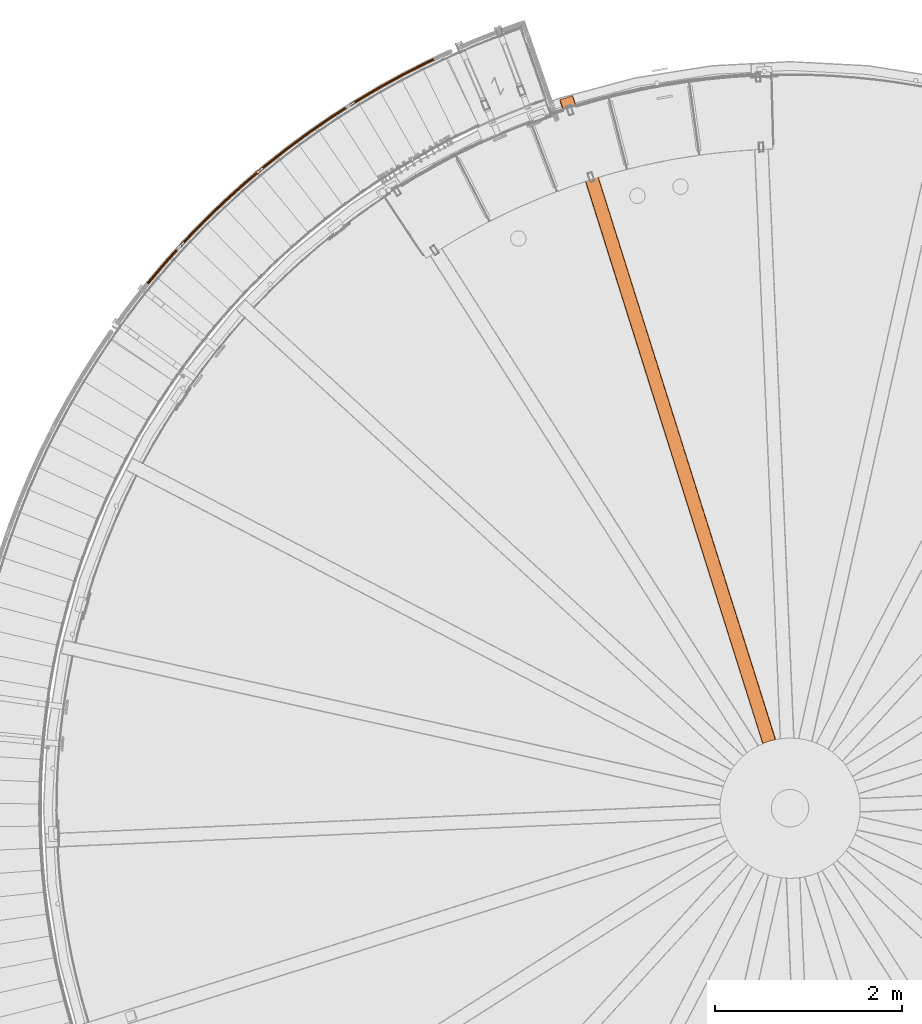
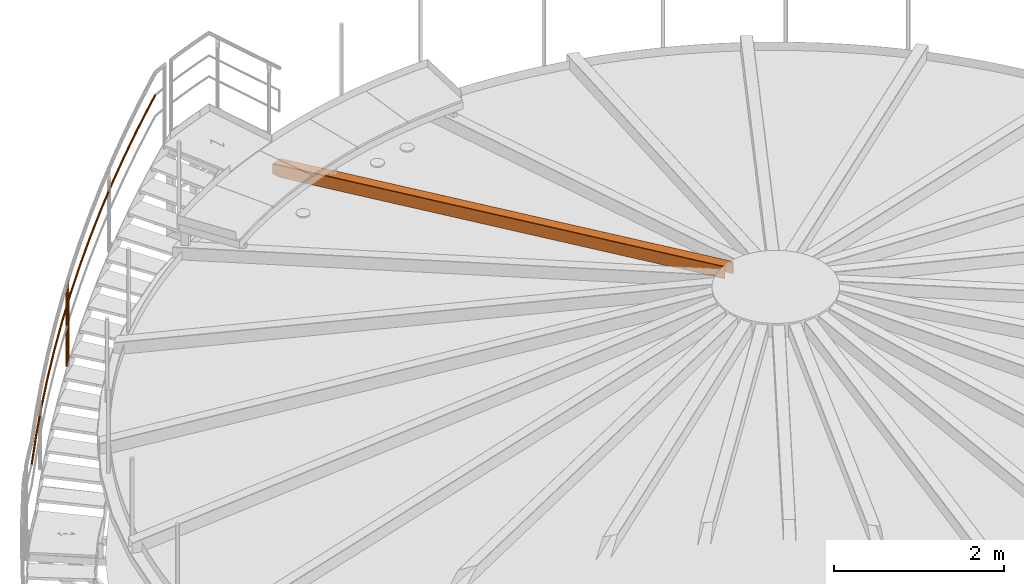
# One storey, part 35 of 126: 3 proxies.
"""IFC2X3 building model written with IfcOpenShell, lengths in millimetres."""

from ifc_helpers import new_model, si_unit, origin, origin_with_axes, place, context, project, spatial, faceted_brep, material, element, save


model = new_model("IFC2X3")

# Units and contexts
context_of_model_1 = context(None, 3, precision=0.1, world=origin())
context_of_model_2 = context(None, 3, precision=0.1, world=origin())
ifc_project = project(units=[si_unit("LENGTHUNIT", "METRE", prefix="MILLI"), si_unit("AREAUNIT", "SQUARE_METRE", prefix="CENTI"), si_unit("VOLUMEUNIT", "CUBIC_METRE", prefix="CENTI"), si_unit("MASSUNIT", "GRAM", prefix="KILO")], contexts=[context_of_model_1, context_of_model_2])

# Site, building, storey
site_placement = place(None, origin_with_axes())
site = spatial("IfcSite", under=ifc_project, at=site_placement, CompositionType="ELEMENT")
building_placement = place(site_placement, origin_with_axes())
building = spatial("IfcBuilding", under=site, at=building_placement, CompositionType="ELEMENT")
storey_placement = place(building_placement, origin_with_axes())
storey = spatial("IfcBuildingStorey", under=building, at=storey_placement, CompositionType="ELEMENT")

# Proxies
ifc_material_1 = material(Name="STAHL")
proxy_1_placement = place(storey_placement, origin_with_axes())
element("IfcBuildingElementProxy", 1, at=proxy_1_placement, inside=storey, material=ifc_material_1, Name="profile", context=context_of_model_2, shape_type="Brep", body=[
    faceted_brep([(7710.0, 8694.5, 12406.2), (7713.7, 8696.1, 12406.1), (7713.7, 8696.1, 12573.8), (7713.8, 8696.1, 12574.5), (7713.9, 8696.2, 12575.2), (7714.2, 8696.3, 12576.0), (7714.7, 8696.5, 12576.6), (7715.2, 8696.7, 12577.1), (7715.8, 8697.0, 12577.5), (7716.5, 8697.3, 12577.8), (7717.4, 8697.7, 12577.9), (7779.5, 8720.3, 12577.1), (7845.3, 8737.8, 12577.9), (7845.7, 8737.9, 12577.9), (7846.1, 8738.0, 12577.8), (7846.9, 8738.2, 12577.6), (7847.7, 8738.3, 12577.1), (7848.2, 8738.4, 12576.5), (7848.7, 8738.5, 12575.8), (7849.1, 8738.6, 12574.9), (7849.2, 8738.6, 12573.9), (7849.2, 8738.6, 12406.2), (7853.1, 8739.5, 12406.3), (7853.1, 8739.5, 12574.0), (7853.0, 8739.4, 12575.4), (7852.6, 8739.4, 12576.8), (7852.0, 8739.2, 12578.2), (7851.1, 8739.0, 12579.5), (7850.0, 8738.8, 12580.5), (7848.7, 8738.5, 12581.3), (7847.1, 8738.2, 12581.9), (7845.3, 8737.8, 12582.1), (7779.5, 8720.3, 12581.2), (7717.4, 8697.7, 12582.0), (7716.6, 8697.3, 12582.0), (7715.7, 8697.0, 12581.8), (7714.2, 8696.3, 12581.3), (7712.9, 8695.8, 12580.4), (7711.8, 8695.3, 12579.2), (7710.9, 8694.9, 12577.8), (7710.2, 8694.6, 12576.0), (7710.0, 8694.5, 12573.9), (5540.8, 15574.3, 10506.0), (5540.8, 15574.3, 10641.0), (5541.0, 15574.4, 10642.6), (5541.4, 15574.5, 10644.2), (5542.3, 15574.8, 10645.9), (5543.5, 15575.2, 10647.3), (5545.0, 15575.6, 10648.4), (5546.7, 15576.2, 10649.1), (5548.4, 15576.7, 10649.3), (5676.2, 15617.0, 10649.3), (5677.7, 15617.5, 10649.2), (5679.2, 15618.0, 10648.7), (5680.7, 15618.4, 10647.7), (5682.0, 15618.9, 10646.4), (5683.0, 15619.2, 10644.8), (5683.7, 15619.4, 10643.0), (5683.9, 15619.4, 10641.0), (5683.9, 15619.4, 10506.0), (5680.0, 15618.2, 10506.0), (5680.0, 15618.2, 10641.0), (5680.0, 15618.2, 10641.8), (5679.8, 15618.1, 10642.6), (5679.3, 15618.0, 10643.5), (5678.7, 15617.8, 10644.2), (5678.0, 15617.6, 10644.7), (5677.1, 15617.3, 10645.1), (5676.2, 15617.0, 10645.2), (5548.4, 15576.7, 10645.2), (5547.7, 15576.5, 10645.1), (5547.0, 15576.3, 10644.9), (5546.2, 15576.0, 10644.4), (5545.5, 15575.8, 10643.7), (5545.0, 15575.7, 10642.9), (5544.7, 15575.6, 10642.0), (5544.6, 15575.5, 10641.0), (5544.6, 15575.5, 10506.0), (5716.7, 15501.9, 10506.0), (5720.5, 15503.1, 10506.0), (5577.5, 15458.0, 10506.0), (5581.3, 15459.2, 10506.0)], [[[0, 1, 2, 3, 4, 5, 6, 7, 8, 9, 10, 11, 12, 13, 14, 15, 16, 17, 18, 19, 20, 21, 22, 23, 24, 25, 26, 27, 28, 29, 30, 31, 32, 33, 34, 35, 36, 37, 38, 39, 40, 41]], [[42, 43, 44, 45, 46, 47, 48, 49, 50, 51, 52, 53, 54, 55, 56, 57, 58, 59, 60, 61, 62, 63, 64, 65, 66, 67, 68, 69, 70, 71, 72, 73, 74, 75, 76, 77]], [[21, 78, 79, 22]], [[24, 23, 22, 79, 59, 58, 57]], [[26, 25, 24, 57, 56]], [[26, 56, 55, 27]], [[27, 55, 54, 28]], [[29, 28, 54, 53]], [[30, 29, 53, 52]], [[35, 34, 33, 32, 31, 30, 52, 51, 50, 49]], [[36, 35, 49, 48]], [[37, 36, 48, 47]], [[38, 37, 47, 46]], [[39, 38, 46, 45]], [[40, 39, 45, 44]], [[0, 41, 40, 44, 43, 42, 80]], [[1, 0, 80, 81]], [[77, 81, 80, 42]], [[60, 59, 79, 78]], [[19, 62, 61, 60, 78, 21, 20]], [[19, 18, 63, 62]], [[18, 17, 64, 63]], [[17, 16, 65, 64]], [[16, 15, 66, 65]], [[15, 14, 67, 66]], [[9, 70, 69, 68, 67, 14, 13, 12, 11, 10]], [[9, 8, 71, 70]], [[8, 7, 72, 71]], [[6, 73, 72, 7]], [[5, 74, 73, 6]], [[3, 75, 74, 5, 4]], [[2, 1, 81, 77, 76, 75, 3]]]),
])
ifc_material_2 = material(Name="S235JRG2")
proxy_2_placement = place(storey_placement, origin_with_axes())
element("IfcBuildingElementProxy", 2, at=proxy_2_placement, inside=storey, material=ifc_material_2, context=context_of_model_2, shape_type="Brep", body=[
    faceted_brep([(1138.8066, 13610.681, 9090.2317), (1134.2211, 13615.725, 9088.8115), (1124.8423, 13603.861, 9078.1524), (1129.9924, 13599.531, 9080.2142), (1132.1521, 13621.046, 9084.8264), (1121.7807, 13607.926, 9073.0392), (1133.1539, 13625.219, 9079.3441), (1121.6279, 13610.638, 9066.2446), (1136.9581, 13627.126, 9073.8336), (1124.4248, 13611.271, 9059.5892), (1142.5454, 13626.255, 9069.7715), (1129.422, 13609.654, 9054.8564), (1148.4187, 13622.841, 9068.2461), (1135.2805, 13606.221, 9053.3143), (1153.0042, 13617.797, 9069.6662), (1140.4306, 13601.891, 9055.376), (1155.0732, 13612.476, 9073.6513), (1143.4922, 13597.826, 9060.4893), (1154.0714, 13608.303, 9079.1336), (1143.645, 13595.113, 9067.2839), (1150.2671, 13606.396, 9084.6441), (1140.8481, 13594.481, 9073.9392), (1144.6798, 13607.267, 9088.7063), (1135.8509, 13596.098, 9078.672), (1139.5212, 13611.585, 9088.597), (1144.5211, 13608.678, 9087.2985), (1135.3729, 13597.106, 9076.9014), (1130.3856, 13600.029, 9078.2142), (1149.2776, 13607.937, 9083.8404), (1139.6271, 13595.729, 9072.8723), (1152.5162, 13609.56, 9079.1493), (1142.0081, 13596.268, 9067.2066), (1153.369, 13613.113, 9074.4822), (1141.878, 13598.577, 9061.4223), (1151.6077, 13617.643, 9071.0897), (1139.2716, 13602.038, 9057.0695), (1147.704, 13621.937, 9069.8807), (1134.8873, 13605.723, 9055.3143), (1142.7041, 13624.843, 9071.1793), (1129.9, 13608.646, 9056.6271), (1137.9476, 13625.584, 9074.6374), (1125.6458, 13610.022, 9060.6561), (1134.7091, 13623.961, 9079.3285), (1123.2648, 13609.484, 9066.3219), (1133.8562, 13620.409, 9083.9956), (1123.395, 13607.175, 9072.1061), (1135.6176, 13615.879, 9087.3881), (1126.0013, 13603.714, 9076.459), (1328.8909, 13835.767, 9297.8784), (1324.4755, 13840.96, 9296.4583), (1322.5845, 13846.347, 9292.4731), (1323.7245, 13850.484, 9286.9908), (1327.5901, 13852.263, 9281.4803), (1333.1453, 13851.208, 9277.4182), (1338.9018, 13847.6, 9275.8928), (1343.3171, 13842.407, 9277.3129), (1345.2082, 13837.02, 9281.298), (1344.0683, 13832.882, 9286.7803), (1340.2028, 13831.103, 9292.2908), (1334.6475, 13832.159, 9296.353), (1329.6352, 13836.646, 9296.2438), (1334.5358, 13833.575, 9294.9452), (1339.265, 13832.676, 9291.487), (1342.5557, 13834.191, 9286.7959), (1343.5261, 13837.713, 9282.1289), (1341.9163, 13842.299, 9278.7364), (1338.1575, 13846.72, 9277.5275), (1333.257, 13849.791, 9278.826), (1328.5278, 13850.69, 9282.2841), (1325.2371, 13849.176, 9286.9752), (1324.2666, 13845.654, 9291.6423), (1325.8764, 13841.067, 9295.0348), (1526.3504, 14054.411, 9505.5251), (1522.1101, 14059.748, 9504.105), (1520.3991, 14065.195, 9500.1198), (1521.676, 14069.292, 9494.6375), (1525.5986, 14070.942, 9489.1271), (1531.1157, 14069.702, 9485.0649), (1536.7491, 14065.905, 9483.5396), (1540.9894, 14060.568, 9484.9597), (1542.7004, 14055.121, 9488.9447), (1541.4236, 14051.024, 9494.427), (1537.5011, 14049.374, 9499.9375), (1531.984, 14050.614, 9503.9997), (1527.1236, 14055.265, 9503.8905), (1531.9194, 14052.033, 9502.592), (1536.6162, 14050.978, 9499.1338), (1539.9554, 14052.382, 9494.4427), (1541.0423, 14055.87, 9489.7756), (1539.5857, 14060.507, 9486.3831), (1535.976, 14065.05, 9485.1742), (1531.1802, 14068.283, 9486.4727), (1526.4835, 14069.338, 9489.9308), (1523.1442, 14067.934, 9494.6219), (1522.0572, 14064.446, 9499.289), (1523.5138, 14059.809, 9502.6816), (1730.967, 14266.372, 9713.1719), (1726.9064, 14271.847, 9711.7517), (1725.3774, 14277.348, 9707.7666), (1726.7897, 14281.401, 9702.2843), (1730.7649, 14282.919, 9696.7738), (1736.2378, 14281.497, 9692.7117), (1741.7419, 14277.514, 9691.1863), (1745.8025, 14272.039, 9692.6064), (1747.3315, 14266.539, 9696.5915), (1745.9193, 14262.486, 9702.0738), (1741.9442, 14260.968, 9707.5843), (1736.4712, 14262.39, 9711.6465), (1731.7681, 14267.201, 9711.5373), (1736.4539, 14263.811, 9710.2387), (1741.113, 14262.6, 9706.7805), (1744.497, 14263.892, 9702.0894), (1745.6993, 14267.342, 9697.4224), (1744.3976, 14272.025, 9694.0299), (1740.9408, 14276.686, 9692.821), (1736.2551, 14280.076, 9694.1195), (1731.5961, 14281.287, 9697.5776), (1728.212, 14279.994, 9702.2686), (1727.0097, 14276.544, 9706.9357), (1728.3113, 14271.862, 9710.3283), (1942.5146, 14471.416, 9920.8186), (1938.6382, 14477.023, 9919.3985), (1937.2929, 14482.572, 9915.4133), (1938.8391, 14486.575, 9909.931), (1942.8625, 14487.961, 9904.4206), (1948.2851, 14486.357, 9900.3584), (1953.6539, 14482.194, 9898.8331), (1957.5302, 14476.588, 9900.2532), (1958.8756, 14471.039, 9904.2382), (1957.3295, 14467.036, 9909.7205), (1953.3061, 14465.65, 9915.231), (1947.8835, 14467.254, 9919.2932), (1943.3428, 14472.218, 9919.184), (1947.9133, 14468.674, 9917.8854), (1952.5296, 14467.309, 9914.4273), (1955.9547, 14468.488, 9909.7362), (1957.271, 14471.897, 9905.0691), (1956.1256, 14476.62, 9901.6766), (1952.8257, 14481.393, 9900.4677), (1948.2552, 14484.937, 9901.7662), (1943.639, 14486.302, 9905.2243), (1940.2138, 14485.123, 9909.9154), (1938.8975, 14481.715, 9914.5825), (1940.0428, 14476.991, 9917.9751), (2160.7596, 14669.317, 10128.465), (2157.0716, 14675.05, 10127.045), (2155.9114, 14680.64, 10123.06), (2157.5898, 14684.59, 10117.578), (2161.6571, 14685.841, 10112.067), (2167.0234, 14684.058, 10108.005), (2172.2508, 14679.719, 10106.48), (2175.9387, 14673.986, 10107.9), (2177.099, 14668.396, 10111.885), (2175.4206, 14664.446, 10117.367), (2171.3534, 14663.195, 10122.878), (2165.9871, 14664.978, 10126.94), (2161.6139, 14670.091, 10126.831), (2166.0641, 14666.397, 10125.532), (2170.6325, 14664.879, 10122.074), (2174.0949, 14665.944, 10117.383), (2175.5237, 14669.307, 10112.716), (2174.536, 14674.066, 10109.323), (2171.3964, 14678.946, 10108.114), (2166.9463, 14682.639, 10109.413), (2162.378, 14684.157, 10112.871), (2158.9155, 14683.092, 10117.562), (2157.4867, 14679.73, 10122.229), (2158.4744, 14674.971, 10125.622), (2385.4607, 14859.856, 10336.112), (2381.9653, 14865.708, 10334.692), (2380.9915, 14871.334, 10330.707), (2382.8003, 14875.225, 10325.225), (2386.9069, 14876.341, 10319.714), (2392.2109, 14874.38, 10315.652), (2397.2913, 14869.87, 10314.127), (2400.7866, 14864.018, 10315.547), (2401.7605, 14858.392, 10319.532), (2399.9518, 14854.501, 10325.014), (2395.8453, 14853.385, 10330.525), (2390.5411, 14855.345, 10334.587), (2386.3403, 14860.6, 10334.478), (2390.6653, 14856.761, 10333.179), (2395.1807, 14855.092, 10329.721), (2398.6766, 14856.041, 10325.03), (2400.2163, 14859.354, 10320.363), (2399.3873, 14864.144, 10316.97), (2396.4117, 14869.125, 10315.761), (2392.0868, 14872.965, 10317.06), (2387.5714, 14874.634, 10320.518), (2384.0755, 14873.684, 10325.209), (2382.5357, 14870.371, 10329.876), (2383.3646, 14865.582, 10333.269), (2616.3698, 15042.822, 10543.759), (2613.0708, 15048.787, 10542.339), (2612.2845, 15054.442, 10538.354), (2614.2216, 15058.271, 10532.871), (2618.363, 15059.249, 10527.361), (2623.599, 15057.114, 10523.299), (2628.5267, 15052.437, 10521.773), (2631.8256, 15046.472, 10523.193), (2632.612, 15040.817, 10527.179), (2630.675, 15036.988, 10532.661), (2626.5336, 15036.01, 10538.171), (2621.2976, 15038.145, 10542.234), (2617.2737, 15043.537, 10542.124), (2621.4687, 15039.555, 10540.826), (2625.9261, 15037.737, 10537.368), (2629.4517, 15038.57, 10532.676), (2631.1006, 15041.83, 10528.009), (2630.4312, 15046.644, 10524.617), (2627.6228, 15051.722, 10523.408), (2623.4279, 15055.704, 10524.707), (2618.9705, 15057.522, 10528.165), (2615.4449, 15056.689, 10532.856), (2613.7959, 15053.429, 10537.523), (2614.4652, 15048.615, 10540.915), (2853.2318, 15218.013, 10751.406), (2850.1329, 15224.084, 10749.986), (2849.535, 15229.762, 10746.0), (2851.5983, 15233.525, 10740.518), (2855.7699, 15234.365, 10735.008), (2860.932, 15232.057, 10730.945), (2865.7015, 15227.219, 10729.42), (2868.8004, 15221.148, 10730.84), (2869.3984, 15215.47, 10734.825), (2867.3352, 15211.707, 10740.308), (2863.1636, 15210.867, 10745.818), (2858.0014, 15213.175, 10749.88), (2854.159, 15218.697, 10749.771), (2858.2193, 15214.579, 10748.472), (2862.6139, 15212.614, 10745.014), (2866.1652, 15213.329, 10740.323), (2867.9216, 15216.532, 10735.656), (2867.4125, 15221.366, 10732.264), (2864.7744, 15226.535, 10731.055), (2860.7141, 15230.653, 10732.353), (2856.3196, 15232.618, 10735.811), (2852.7683, 15231.903, 10740.502), (2851.0118, 15228.7, 10745.17), (2851.5208, 15223.866, 10748.562), (3095.7851, 15385.236, 10959.052), (3092.8896, 15391.407, 10957.632), (3092.4807, 15397.101, 10953.647), (3094.6679, 15400.794, 10948.165), (3098.8652, 15401.495, 10942.654), (3103.9477, 15399.016, 10938.592), (3108.5538, 15394.022, 10937.067), (3111.4493, 15387.852, 10938.487), (3111.8582, 15382.157, 10942.472), (3109.6711, 15378.464, 10947.954), (3105.4739, 15377.763, 10953.465), (3100.3913, 15380.242, 10957.527), (3096.7344, 15385.889, 10957.418), (3100.6557, 15381.638, 10956.119), (3104.9825, 15379.528, 10952.661), (3108.5556, 15380.125, 10947.97), (3110.4175, 15383.268, 10943.303), (3110.0694, 15388.116, 10939.91), (3107.6045, 15393.369, 10938.701), (3103.6833, 15397.62, 10940.0), (3099.3565, 15399.73, 10943.458), (3095.7834, 15399.134, 10948.149), (3093.9214, 15395.99, 10952.816), (3094.2695, 15391.142, 10956.209), (3343.7616, 15544.306, 11166.699), (3341.0729, 15550.569, 11165.279), (3340.8534, 15556.275, 11161.294), (3343.1621, 15559.892, 11155.812), (3347.3803, 15560.453, 11150.301), (3352.3777, 15557.807, 11146.239), (3356.8153, 15552.663, 11144.714), (3359.5041, 15546.399, 11146.134), (3359.7236, 15540.694, 11150.119), (3357.4149, 15537.076, 11155.601), (3353.1968, 15536.515, 11161.112), (3348.1993, 15539.161, 11165.174), (3344.7322, 15544.927, 11165.065), (3348.51, 15540.548, 11163.766), (3352.7643, 15538.295, 11160.308), (3356.3552, 15538.773, 11155.617), (3358.3206, 15541.853, 11150.95), (3358.1337, 15546.709, 11147.557), (3355.8448, 15552.042, 11146.348), (3352.067, 15556.421, 11147.647), (3347.8127, 15558.673, 11151.105), (3344.2218, 15558.196, 11155.796), (3342.2564, 15555.116, 11160.463), (3342.4432, 15550.259, 11163.856), (3596.8875, 15695.047, 11374.346), (3594.4084, 15701.396, 11372.926), (3594.3787, 15707.106, 11368.941), (3596.8063, 15710.645, 11363.458), (3601.0408, 15711.065, 11357.948), (3605.9475, 15708.254, 11353.886), (3610.2117, 15702.966, 11352.36), (3612.6908, 15696.616, 11353.78), (3612.7206, 15690.907, 11357.766), (3610.293, 15687.368, 11363.248), (3606.0586, 15686.947, 11368.758), (3601.1518, 15689.758, 11372.821), (3597.8782, 15695.635, 11372.711), (3601.5083, 15691.133, 11371.413), (3605.6855, 15688.74, 11367.955), (3609.2903, 15689.098, 11363.263), (3611.3569, 15692.111, 11358.596), (3611.3315, 15696.971, 11355.204), (3609.2211, 15702.377, 11353.995), (3605.591, 15706.879, 11355.294), (3601.4139, 15709.272, 11358.752), (3597.809, 15708.914, 11363.443), (3595.7424, 15705.901, 11368.11), (3595.7677, 15701.041, 11371.502), (3854.8831, 15837.292, 11581.993), (3852.6163, 15843.721, 11580.573), (3852.7764, 15849.428, 11576.587), (3855.3203, 15852.884, 11571.105), (3859.5664, 15853.164, 11565.594), (3864.377, 15850.192, 11561.532), (3868.4631, 15844.764, 11560.007), (3870.7298, 15838.336, 11561.427), (3870.5699, 15832.629, 11565.412), (3868.026, 15829.172, 11570.895), (3863.7799, 15828.893, 11576.405), (3858.9693, 15831.865, 11580.467), (3855.8928, 15837.848, 11580.358), (3859.3713, 15833.227, 11579.059), (3863.4666, 15830.697, 11575.601), (3867.0813, 15830.935, 11570.91), (3869.2469, 15833.878, 11566.243), (3869.3831, 15838.736, 11562.851), (3867.4534, 15844.209, 11561.642), (3863.975, 15848.829, 11562.94), (3859.8797, 15851.359, 11566.398), (3856.265, 15851.121, 11571.089), (3854.0993, 15848.179, 11575.757), (3853.9631, 15843.32, 11579.149), (4117.4634, 15970.886, 11789.639), (4115.4115, 15977.386, 11788.219), (4115.7611, 15983.085, 11784.234), (4118.4185, 15986.454, 11778.752), (4122.6716, 15986.593, 11773.241), (4127.3807, 15983.462, 11769.179), (4131.2842, 15977.902, 11767.654), (4133.336, 15971.402, 11769.074), (4132.9865, 15965.703, 11773.059), (4130.3292, 15962.333, 11778.541), (4126.0761, 15962.195, 11784.052), (4121.3669, 15965.325, 11788.114), (4118.4909, 15971.407, 11788.005), (4121.814, 15966.674, 11786.706), (4125.823, 15964.009, 11783.248), (4129.4436, 15964.127, 11778.557), (4131.7058, 15966.995, 11773.89), (4132.0034, 15971.847, 11770.497), (4130.2566, 15977.38, 11769.288), (4126.9336, 15982.114, 11770.587), (4122.9247, 15984.779, 11774.045), (4119.304, 15984.661, 11778.736), (4117.0418, 15981.792, 11783.403), (4116.7442, 15976.941, 11786.796), (4197.2202, 16008.181, 11851.696), (4194.9624, 16014.574, 11850.065), (4194.3236, 16019.78, 11845.268), (4195.4744, 16022.405, 11838.591), (4198.1066, 16021.747, 11831.821), (4201.5151, 16017.981, 11826.772), (4204.7873, 16012.116, 11824.796), (4207.0464, 16005.722, 11826.424), (4207.6866, 16000.513, 11831.22), (4206.5358, 15997.886, 11837.9), (4203.9024, 15998.545, 11844.673), (4200.4925, 16002.313, 11849.722), (4197.7831, 16008.472, 11849.696), (4200.5688, 16003.478, 11848.016), (4203.4716, 16000.27, 11843.717), (4205.7134, 15999.709, 11837.951), (4206.693, 16001.946, 11832.265), (4206.1481, 16006.38, 11828.182), (4204.225, 16011.823, 11826.796), (4201.4394, 16016.816, 11828.478), (4198.5376, 16020.022, 11832.776), (4196.2968, 16020.582, 11838.539), (4195.3171, 16018.347, 11844.224), (4195.861, 16013.915, 11848.308)], [[[0, 1, 2, 3]], [[1, 4, 5, 2]], [[4, 6, 7, 5]], [[6, 8, 9, 7]], [[8, 10, 11, 9]], [[10, 12, 13, 11]], [[12, 14, 15, 13]], [[14, 16, 17, 15]], [[16, 18, 19, 17]], [[18, 20, 21, 19]], [[20, 22, 23, 21]], [[0, 3, 23, 22]], [[24, 25, 26, 27]], [[25, 28, 29, 26]], [[28, 30, 31, 29]], [[30, 32, 33, 31]], [[32, 34, 35, 33]], [[34, 36, 37, 35]], [[36, 38, 39, 37]], [[38, 40, 41, 39]], [[40, 42, 43, 41]], [[42, 44, 45, 43]], [[44, 46, 47, 45]], [[24, 27, 47, 46]], [[0, 48, 49, 1]], [[1, 49, 50, 4]], [[4, 50, 51, 6]], [[6, 51, 52, 8]], [[8, 52, 53, 10]], [[10, 53, 54, 12]], [[12, 54, 55, 14]], [[14, 55, 56, 16]], [[16, 56, 57, 18]], [[18, 57, 58, 20]], [[20, 58, 59, 22]], [[22, 59, 48, 0]], [[24, 60, 61, 25]], [[25, 61, 62, 28]], [[28, 62, 63, 30]], [[30, 63, 64, 32]], [[32, 64, 65, 34]], [[34, 65, 66, 36]], [[36, 66, 67, 38]], [[38, 67, 68, 40]], [[40, 68, 69, 42]], [[42, 69, 70, 44]], [[44, 70, 71, 46]], [[46, 71, 60, 24]], [[48, 72, 73, 49]], [[49, 73, 74, 50]], [[50, 74, 75, 51]], [[51, 75, 76, 52]], [[52, 76, 77, 53]], [[53, 77, 78, 54]], [[54, 78, 79, 55]], [[55, 79, 80, 56]], [[56, 80, 81, 57]], [[57, 81, 82, 58]], [[58, 82, 83, 59]], [[59, 83, 72, 48]], [[60, 84, 85, 61]], [[61, 85, 86, 62]], [[62, 86, 87, 63]], [[63, 87, 88, 64]], [[64, 88, 89, 65]], [[65, 89, 90, 66]], [[66, 90, 91, 67]], [[67, 91, 92, 68]], [[68, 92, 93, 69]], [[69, 93, 94, 70]], [[70, 94, 95, 71]], [[71, 95, 84, 60]], [[72, 96, 97, 73]], [[73, 97, 98, 74]], [[74, 98, 99, 75]], [[75, 99, 100, 76]], [[76, 100, 101, 77]], [[77, 101, 102, 78]], [[78, 102, 103, 79]], [[79, 103, 104, 80]], [[80, 104, 105, 81]], [[81, 105, 106, 82]], [[82, 106, 107, 83]], [[83, 107, 96, 72]], [[84, 108, 109, 85]], [[85, 109, 110, 86]], [[86, 110, 111, 87]], [[87, 111, 112, 88]], [[88, 112, 113, 89]], [[89, 113, 114, 90]], [[90, 114, 115, 91]], [[91, 115, 116, 92]], [[92, 116, 117, 93]], [[93, 117, 118, 94]], [[94, 118, 119, 95]], [[95, 119, 108, 84]], [[96, 120, 121, 97]], [[97, 121, 122, 98]], [[98, 122, 123, 99]], [[99, 123, 124, 100]], [[100, 124, 125, 101]], [[101, 125, 126, 102]], [[102, 126, 127, 103]], [[103, 127, 128, 104]], [[104, 128, 129, 105]], [[105, 129, 130, 106]], [[106, 130, 131, 107]], [[107, 131, 120, 96]], [[108, 132, 133, 109]], [[109, 133, 134, 110]], [[110, 134, 135, 111]], [[111, 135, 136, 112]], [[112, 136, 137, 113]], [[113, 137, 138, 114]], [[114, 138, 139, 115]], [[115, 139, 140, 116]], [[116, 140, 141, 117]], [[117, 141, 142, 118]], [[118, 142, 143, 119]], [[119, 143, 132, 108]], [[120, 144, 145, 121]], [[121, 145, 146, 122]], [[122, 146, 147, 123]], [[123, 147, 148, 124]], [[124, 148, 149, 125]], [[125, 149, 150, 126]], [[126, 150, 151, 127]], [[127, 151, 152, 128]], [[128, 152, 153, 129]], [[129, 153, 154, 130]], [[130, 154, 155, 131]], [[131, 155, 144, 120]], [[132, 156, 157, 133]], [[133, 157, 158, 134]], [[134, 158, 159, 135]], [[135, 159, 160, 136]], [[136, 160, 161, 137]], [[137, 161, 162, 138]], [[138, 162, 163, 139]], [[139, 163, 164, 140]], [[140, 164, 165, 141]], [[141, 165, 166, 142]], [[142, 166, 167, 143]], [[143, 167, 156, 132]], [[144, 168, 169, 145]], [[145, 169, 170, 146]], [[146, 170, 171, 147]], [[147, 171, 172, 148]], [[148, 172, 173, 149]], [[149, 173, 174, 150]], [[150, 174, 175, 151]], [[151, 175, 176, 152]], [[152, 176, 177, 153]], [[153, 177, 178, 154]], [[154, 178, 179, 155]], [[155, 179, 168, 144]], [[156, 180, 181, 157]], [[157, 181, 182, 158]], [[158, 182, 183, 159]], [[159, 183, 184, 160]], [[160, 184, 185, 161]], [[161, 185, 186, 162]], [[162, 186, 187, 163]], [[163, 187, 188, 164]], [[164, 188, 189, 165]], [[165, 189, 190, 166]], [[166, 190, 191, 167]], [[167, 191, 180, 156]], [[168, 192, 193, 169]], [[169, 193, 194, 170]], [[170, 194, 195, 171]], [[171, 195, 196, 172]], [[172, 196, 197, 173]], [[173, 197, 198, 174]], [[174, 198, 199, 175]], [[175, 199, 200, 176]], [[176, 200, 201, 177]], [[177, 201, 202, 178]], [[178, 202, 203, 179]], [[179, 203, 192, 168]], [[180, 204, 205, 181]], [[181, 205, 206, 182]], [[182, 206, 207, 183]], [[183, 207, 208, 184]], [[184, 208, 209, 185]], [[185, 209, 210, 186]], [[186, 210, 211, 187]], [[187, 211, 212, 188]], [[188, 212, 213, 189]], [[189, 213, 214, 190]], [[190, 214, 215, 191]], [[191, 215, 204, 180]], [[192, 216, 217, 193]], [[193, 217, 218, 194]], [[194, 218, 219, 195]], [[195, 219, 220, 196]], [[196, 220, 221, 197]], [[197, 221, 222, 198]], [[198, 222, 223, 199]], [[199, 223, 224, 200]], [[200, 224, 225, 201]], [[201, 225, 226, 202]], [[202, 226, 227, 203]], [[203, 227, 216, 192]], [[204, 228, 229, 205]], [[205, 229, 230, 206]], [[206, 230, 231, 207]], [[207, 231, 232, 208]], [[208, 232, 233, 209]], [[209, 233, 234, 210]], [[210, 234, 235, 211]], [[211, 235, 236, 212]], [[212, 236, 237, 213]], [[213, 237, 238, 214]], [[214, 238, 239, 215]], [[215, 239, 228, 204]], [[216, 240, 241, 217]], [[217, 241, 242, 218]], [[218, 242, 243, 219]], [[219, 243, 244, 220]], [[220, 244, 245, 221]], [[221, 245, 246, 222]], [[222, 246, 247, 223]], [[223, 247, 248, 224]], [[224, 248, 249, 225]], [[225, 249, 250, 226]], [[226, 250, 251, 227]], [[227, 251, 240, 216]], [[228, 252, 253, 229]], [[229, 253, 254, 230]], [[230, 254, 255, 231]], [[231, 255, 256, 232]], [[232, 256, 257, 233]], [[233, 257, 258, 234]], [[234, 258, 259, 235]], [[235, 259, 260, 236]], [[236, 260, 261, 237]], [[237, 261, 262, 238]], [[238, 262, 263, 239]], [[239, 263, 252, 228]], [[240, 264, 265, 241]], [[241, 265, 266, 242]], [[242, 266, 267, 243]], [[243, 267, 268, 244]], [[244, 268, 269, 245]], [[245, 269, 270, 246]], [[246, 270, 271, 247]], [[247, 271, 272, 248]], [[248, 272, 273, 249]], [[249, 273, 274, 250]], [[250, 274, 275, 251]], [[251, 275, 264, 240]], [[252, 276, 277, 253]], [[253, 277, 278, 254]], [[254, 278, 279, 255]], [[255, 279, 280, 256]], [[256, 280, 281, 257]], [[257, 281, 282, 258]], [[258, 282, 283, 259]], [[259, 283, 284, 260]], [[260, 284, 285, 261]], [[261, 285, 286, 262]], [[262, 286, 287, 263]], [[263, 287, 276, 252]], [[264, 288, 289, 265]], [[265, 289, 290, 266]], [[266, 290, 291, 267]], [[267, 291, 292, 268]], [[268, 292, 293, 269]], [[269, 293, 294, 270]], [[270, 294, 295, 271]], [[271, 295, 296, 272]], [[272, 296, 297, 273]], [[273, 297, 298, 274]], [[274, 298, 299, 275]], [[275, 299, 288, 264]], [[276, 300, 301, 277]], [[277, 301, 302, 278]], [[278, 302, 303, 279]], [[279, 303, 304, 280]], [[280, 304, 305, 281]], [[281, 305, 306, 282]], [[282, 306, 307, 283]], [[283, 307, 308, 284]], [[284, 308, 309, 285]], [[285, 309, 310, 286]], [[286, 310, 311, 287]], [[287, 311, 300, 276]], [[288, 312, 313, 289]], [[289, 313, 314, 290]], [[290, 314, 315, 291]], [[291, 315, 316, 292]], [[292, 316, 317, 293]], [[293, 317, 318, 294]], [[294, 318, 319, 295]], [[295, 319, 320, 296]], [[296, 320, 321, 297]], [[297, 321, 322, 298]], [[298, 322, 323, 299]], [[299, 323, 312, 288]], [[300, 324, 325, 301]], [[301, 325, 326, 302]], [[302, 326, 327, 303]], [[303, 327, 328, 304]], [[304, 328, 329, 305]], [[305, 329, 330, 306]], [[306, 330, 331, 307]], [[307, 331, 332, 308]], [[308, 332, 333, 309]], [[309, 333, 334, 310]], [[310, 334, 335, 311]], [[311, 335, 324, 300]], [[312, 336, 337, 313]], [[313, 337, 338, 314]], [[314, 338, 339, 315]], [[315, 339, 340, 316]], [[316, 340, 341, 317]], [[317, 341, 342, 318]], [[318, 342, 343, 319]], [[319, 343, 344, 320]], [[320, 344, 345, 321]], [[321, 345, 346, 322]], [[322, 346, 347, 323]], [[323, 347, 336, 312]], [[324, 348, 349, 325]], [[325, 349, 350, 326]], [[326, 350, 351, 327]], [[327, 351, 352, 328]], [[328, 352, 353, 329]], [[329, 353, 354, 330]], [[330, 354, 355, 331]], [[331, 355, 356, 332]], [[332, 356, 357, 333]], [[333, 357, 358, 334]], [[334, 358, 359, 335]], [[335, 359, 348, 324]], [[336, 360, 361, 337]], [[337, 361, 362, 338]], [[338, 362, 363, 339]], [[339, 363, 364, 340]], [[340, 364, 365, 341]], [[341, 365, 366, 342]], [[342, 366, 367, 343]], [[343, 367, 368, 344]], [[344, 368, 369, 345]], [[345, 369, 370, 346]], [[346, 370, 371, 347]], [[336, 347, 371, 360]], [[348, 372, 373, 349]], [[349, 373, 374, 350]], [[350, 374, 375, 351]], [[351, 375, 376, 352]], [[352, 376, 377, 353]], [[353, 377, 378, 354]], [[354, 378, 379, 355]], [[355, 379, 380, 356]], [[356, 380, 381, 357]], [[357, 381, 382, 358]], [[358, 382, 383, 359]], [[348, 359, 383, 372]], [[7, 9, 11, 13, 15, 17, 19, 21, 23, 3, 2, 5], [26, 29, 31, 33, 35, 37, 39, 41, 43, 45, 47, 27]], [[360, 371, 370, 369, 368, 367, 366, 365, 364, 363, 362, 361], [372, 383, 382, 381, 380, 379, 378, 377, 376, 375, 374, 373]]]),
])
ifc_material_3 = material(Name="1.4462")
proxy_3_placement = place(storey_placement, origin_with_axes())
element("IfcBuildingElementProxy", 3, at=proxy_3_placement, inside=storey, material=ifc_material_3, Name="Pfosten", context=context_of_model_2, shape_type="Brep", body=[
    faceted_brep([(2289.5673, 14778.686, 10394.101), (2284.2354, 14789.993, 10394.101), (2284.2354, 14789.993, 9350.2446), (2289.5673, 14778.686, 9350.2436), (2285.2713, 14802.45, 10394.101), (2285.2713, 14802.45, 9350.2472), (2292.3974, 14812.721, 10394.101), (2292.3974, 14812.721, 9350.2508), (2303.7043, 14818.053, 10394.101), (2303.7043, 14818.053, 9350.2545), (2316.1622, 14817.017, 10394.101), (2316.1622, 14817.017, 9350.2571), (2326.4332, 14809.891, 10394.101), (2326.4332, 14809.891, 9350.2581), (2331.7651, 14798.584, 10394.101), (2331.7651, 14798.584, 9350.2571), (2330.7291, 14786.126, 10394.101), (2330.7291, 14786.126, 9350.2545), (2323.603, 14775.856, 10394.101), (2323.603, 14775.856, 9350.2508), (2312.2962, 14770.524, 10394.101), (2312.2962, 14770.524, 9350.2472), (2299.8382, 14771.559, 10394.101), (2299.8382, 14771.559, 9350.2446), (2328.3763, 14786.971, 10394.101), (2329.3049, 14798.14, 10394.101), (2329.3049, 14798.14, 9350.2565), (2328.3763, 14786.971, 9350.2541), (2324.525, 14808.276, 10394.101), (2324.525, 14808.276, 9350.2573), (2315.3173, 14814.665, 10394.101), (2315.3173, 14814.665, 9350.2565), (2304.149, 14815.593, 10394.101), (2304.149, 14815.593, 9350.2541), (2294.0126, 14810.813, 10394.101), (2294.0126, 14810.813, 9350.2508), (2287.6242, 14801.606, 10394.101), (2287.6242, 14801.606, 9350.2476), (2286.6955, 14790.437, 10394.101), (2286.6955, 14790.437, 9350.2452), (2291.4754, 14780.301, 10394.101), (2291.4754, 14780.301, 9350.2443), (2300.6831, 14773.912, 10394.101), (2300.6831, 14773.912, 9350.2452), (2311.8515, 14772.984, 10394.101), (2311.8515, 14772.984, 9350.2476), (2321.9878, 14777.764, 10394.101), (2321.9878, 14777.764, 9350.2508), (2280.135, 14770.701, 10442.401), (2279.5517, 14772.524, 10442.401), (2280.4279, 14774.225, 10442.401), (2306.385, 14796.197, 10442.401), (2332.3421, 14818.168, 10442.401), (2334.1645, 14818.752, 10442.401), (2335.8655, 14817.875, 10442.401), (2336.4487, 14816.053, 10442.401), (2335.5725, 14814.352, 10442.401), (2309.6154, 14792.38, 10442.401), (2283.6583, 14770.409, 10442.401), (2281.836, 14769.825, 10442.401), (2334.0865, 14816.108, 10442.401), (2334.1566, 14816.244, 10442.401), (2334.11, 14816.389, 10442.401), (2333.9739, 14816.46, 10442.401), (2333.8281, 14816.413, 10442.401), (2307.871, 14794.441, 10442.401), (2281.9139, 14772.469, 10442.401), (2281.8438, 14772.333, 10442.401), (2281.8905, 14772.188, 10442.401), (2282.0266, 14772.117, 10442.401), (2282.1724, 14772.164, 10442.401), (2308.1294, 14794.136, 10442.401), (2280.135, 14770.701, 10513.663), (2279.5517, 14772.524, 10514.178), (2280.4279, 14774.225, 10515.422), (2306.385, 14796.197, 10539.357), (2332.3421, 14818.168, 10563.293), (2334.1645, 14818.752, 10564.537), (2335.8655, 14817.875, 10565.052), (2336.4487, 14816.053, 10564.537), (2335.5725, 14814.352, 10563.293), (2309.6154, 14792.38, 10539.357), (2283.6583, 14770.409, 10515.422), (2281.836, 14769.825, 10514.178), (2334.0865, 14816.108, 10563.293), (2334.1566, 14816.244, 10563.392), (2334.11, 14816.389, 10563.433), (2333.9739, 14816.46, 10563.392), (2333.8281, 14816.413, 10563.293), (2307.871, 14794.441, 10539.357), (2281.9139, 14772.469, 10515.422), (2281.8438, 14772.333, 10515.323), (2281.8905, 14772.188, 10515.281), (2282.0266, 14772.117, 10515.323), (2282.1724, 14772.164, 10515.422), (2308.1294, 14794.136, 10539.357)], [[[0, 1, 2, 3]], [[1, 4, 5, 2]], [[4, 6, 7, 5]], [[6, 8, 9, 7]], [[8, 10, 11, 9]], [[10, 12, 13, 11]], [[12, 14, 15, 13]], [[14, 16, 17, 15]], [[16, 18, 19, 17]], [[18, 20, 21, 19]], [[20, 22, 23, 21]], [[0, 3, 23, 22]], [[24, 25, 26, 27]], [[25, 28, 29, 26]], [[28, 30, 31, 29]], [[30, 32, 33, 31]], [[32, 34, 35, 33]], [[34, 36, 37, 35]], [[36, 38, 39, 37]], [[38, 40, 41, 39]], [[40, 42, 43, 41]], [[42, 44, 45, 43]], [[44, 46, 47, 45]], [[24, 27, 47, 46]], [[0, 48, 49, 1]], [[1, 49, 50, 4]], [[4, 50, 51, 6]], [[6, 51, 52, 8]], [[8, 52, 53, 10]], [[10, 53, 54, 12]], [[12, 54, 55, 14]], [[14, 55, 56, 16]], [[16, 56, 57, 18]], [[18, 57, 58, 20]], [[20, 58, 59, 22]], [[22, 59, 48, 0]], [[24, 60, 61, 25]], [[25, 61, 62, 28]], [[28, 62, 63, 30]], [[30, 63, 64, 32]], [[32, 64, 65, 34]], [[34, 65, 66, 36]], [[36, 66, 67, 38]], [[38, 67, 68, 40]], [[40, 68, 69, 42]], [[42, 69, 70, 44]], [[44, 70, 71, 46]], [[46, 71, 60, 24]], [[48, 72, 73, 49]], [[49, 73, 74, 50]], [[50, 74, 75, 51]], [[51, 75, 76, 52]], [[52, 76, 77, 53]], [[53, 77, 78, 54]], [[54, 78, 79, 55]], [[55, 79, 80, 56]], [[56, 80, 81, 57]], [[57, 81, 82, 58]], [[58, 82, 83, 59]], [[48, 59, 83, 72]], [[60, 84, 85, 61]], [[61, 85, 86, 62]], [[62, 86, 87, 63]], [[63, 87, 88, 64]], [[64, 88, 89, 65]], [[65, 89, 90, 66]], [[66, 90, 91, 67]], [[67, 91, 92, 68]], [[68, 92, 93, 69]], [[69, 93, 94, 70]], [[70, 94, 95, 71]], [[60, 71, 95, 84]], [[7, 9, 11, 13, 15, 17, 19, 21, 23, 3, 2, 5], [26, 29, 31, 33, 35, 37, 39, 41, 43, 45, 47, 27]], [[74, 73, 72, 83, 82, 81, 80, 79, 78, 77, 76, 75], [84, 95, 94, 93, 92, 91, 90, 89, 88, 87, 86, 85]]]),
])

save(model, "model.ifc")
